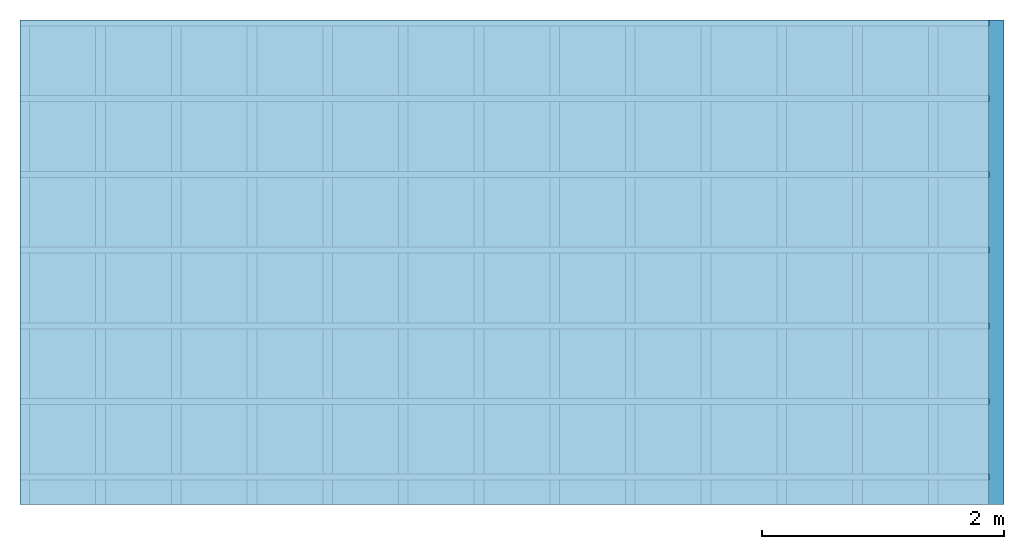
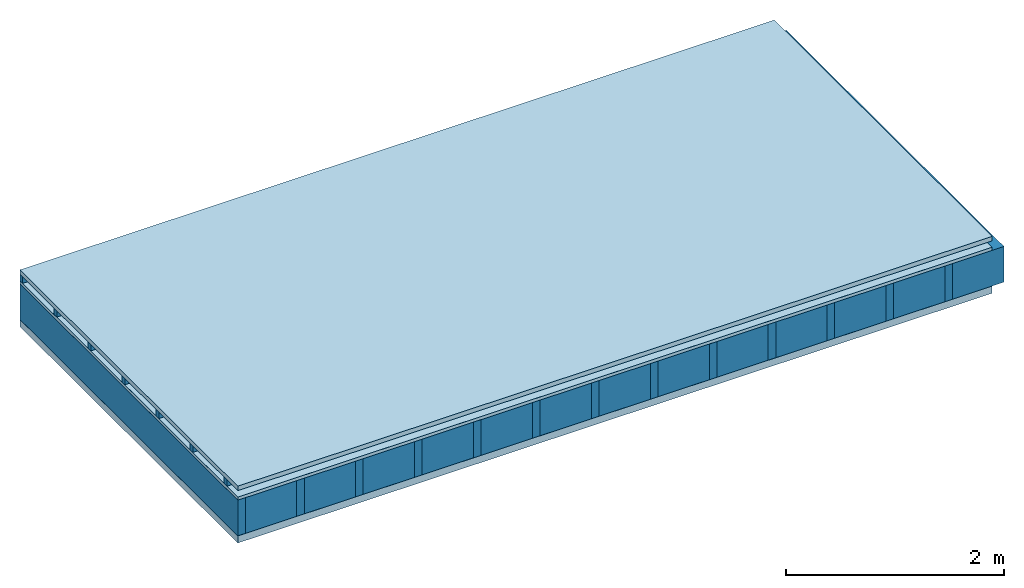
# One storey: 5 plates, 3 members, 1 element without a shape of its own.
"""IFC4 building model written with IfcOpenShell, lengths in metres."""

from ifc_helpers import new_model, si_unit, derived_unit, direction, frame, frame_2d, origin, origin_with_axes, place, context, project, spatial, rectangle, extrude, material, layer, layer_set, type_object, element, aggregate, save


model = new_model("IFC4")

# Units and contexts
plan_context = context("Plan", 3, precision=1e-05, world=origin(), true_north=direction((0.0, 1.0)))
model_context = context("Model", 3, precision=1e-05, world=origin(), true_north=direction((0.0, 1.0)))
ifc_project = project(units=[si_unit("LENGTHUNIT", "METRE"), derived_unit("SOUNDPRESSUREUNIT", [(si_unit("PRESSUREUNIT", "PASCAL", prefix="MICRO"), 0)]), si_unit("ENERGYUNIT", "JOULE", prefix="MEGA"), si_unit("MASSUNIT", "GRAM", prefix="KILO"), derived_unit("THERMALTRANSMITTANCEUNIT", [(si_unit("POWERUNIT", "WATT"), 1), (si_unit("AREAUNIT", "SQUARE_METRE"), -1), (si_unit("THERMODYNAMICTEMPERATUREUNIT", "KELVIN"), -1)]), derived_unit("AREADENSITYUNIT", [(si_unit("MASSUNIT", "GRAM", prefix="KILO"), 1), (si_unit("AREAUNIT", "SQUARE_METRE"), -1)]), derived_unit("USERDEFINED", [(si_unit("ENERGYUNIT", "JOULE", prefix="MEGA"), 1), (si_unit("AREAUNIT", "SQUARE_METRE"), -1)])], contexts=[plan_context, model_context])

# Site, building, storey
site = spatial("IfcSite", under=ifc_project)
building_placement = place(None, origin())
building = spatial("IfcBuilding", under=site, at=building_placement)
storey_placement = place(building_placement, origin())
storey = spatial("IfcBuildingStorey", under=building, at=storey_placement)

# Slab, members, plates
ifc_material_1 = material(Name="Roof tiles", Category="03.015")
ifc_layer_1 = layer(ifc_material_1, 0.05, Name="Roofing")
ifc_layer_2 = layer(None, 0.072, Name="Battens / profiles")
ifc_material_2 = material(Name="Roofing underlay", Category="09.008")
ifc_layer_3 = layer(ifc_material_2, 0.00018, Name="Under the roof")
ifc_material_3 = material(Category="10.009")
ifc_layer_4 = layer(ifc_material_3, 0.035, Name="Sub-floor")
ifc_material_4 = material(Name="of the art")
ifc_layer_5 = layer(ifc_material_4, 0.0, Name="Bond")
ifc_layer_6 = layer(None, 0.4, Name="Supporting structure")
ifc_material_5 = material(Name="Vapor barrier polyethylene (PE)", Category="09.002")
ifc_layer_7 = layer(ifc_material_5, 0.00025, Name="Lower layer 1")
ifc_material_6 = material(Name="Solid timber panel")
ifc_layer_8 = layer(ifc_material_6, 0.08, Name="Lower 2nd layer")
ifc_layer_set = layer_set([ifc_layer_1, ifc_layer_2, ifc_layer_3, ifc_layer_4, ifc_layer_5, ifc_layer_6, ifc_layer_7, ifc_layer_8])
slab_type = type_object("IfcSlabType", Name="E0151", PredefinedType="NOTDEFINED", material=ifc_layer_set)
slab_placement = place(None, frame((0.0, 0.0, 0.0), z_axis=(0.0, 0.0, -1.0), x_axis=(1.0, 0.0, 0.0)))
slab = element("IfcSlab", 1, at=slab_placement, inside=storey, type_object=slab_type, material=ifc_layer_set, Name="Slab #1")
ifc_material_7 = material()
member_1_placement = place(slab_placement, origin())
member_1 = element("IfcMember", 2, at=member_1_placement, material=ifc_material_7, Name="Battens / profiles", context=plan_context, shape_type="SweptSolid", body=[
    extrude(rectangle(XDim=0.05, YDim=0.072, at=frame_2d((0.025, 0.036), x_axis=(1.0, 0.0))), frame((0.0, 0.0, 0.05), z_axis=(1.0, 0.0, 0.0), x_axis=(0.0, 1.0, 0.0)), (0.0, 0.0, 1.0), 8.0),
    extrude(rectangle(XDim=0.05, YDim=0.072, at=frame_2d((0.025, 0.036), x_axis=(1.0, 0.0))), frame((0.0, 0.625, 0.05), z_axis=(1.0, 0.0, 0.0), x_axis=(0.0, 1.0, 0.0)), (0.0, 0.0, 1.0), 8.0),
    extrude(rectangle(XDim=0.05, YDim=0.072, at=frame_2d((0.025, 0.036), x_axis=(1.0, 0.0))), frame((0.0, 1.25, 0.05), z_axis=(1.0, 0.0, 0.0), x_axis=(0.0, 1.0, 0.0)), (0.0, 0.0, 1.0), 8.0),
    extrude(rectangle(XDim=0.05, YDim=0.072, at=frame_2d((0.025, 0.036), x_axis=(1.0, 0.0))), frame((0.0, 1.875, 0.05), z_axis=(1.0, 0.0, 0.0), x_axis=(0.0, 1.0, 0.0)), (0.0, 0.0, 1.0), 8.0),
    extrude(rectangle(XDim=0.05, YDim=0.072, at=frame_2d((0.025, 0.036), x_axis=(1.0, 0.0))), frame((0.0, 2.5, 0.05), z_axis=(1.0, 0.0, 0.0), x_axis=(0.0, 1.0, 0.0)), (0.0, 0.0, 1.0), 8.0),
    extrude(rectangle(XDim=0.05, YDim=0.072, at=frame_2d((0.025, 0.036), x_axis=(1.0, 0.0))), frame((0.0, 3.125, 0.05), z_axis=(1.0, 0.0, 0.0), x_axis=(0.0, 1.0, 0.0)), (0.0, 0.0, 1.0), 8.0),
    extrude(rectangle(XDim=0.05, YDim=0.072, at=frame_2d((0.025, 0.036), x_axis=(1.0, 0.0))), frame((0.0, 3.75, 0.05), z_axis=(1.0, 0.0, 0.0), x_axis=(0.0, 1.0, 0.0)), (0.0, 0.0, 1.0), 8.0),
])
ifc_material_8 = material()
member_2_placement = place(slab_placement, origin())
member_2 = element("IfcMember", 3, at=member_2_placement, material=ifc_material_8, Name="Supporting structure", context=plan_context, shape_type="SweptSolid", body=[
    extrude(rectangle(XDim=0.08, YDim=0.4, at=frame_2d((0.04, 0.2), x_axis=(1.0, 0.0))), frame((0.0, 4.0, 0.15718), z_axis=(0.0, -1.0, 0.0), x_axis=(1.0, 0.0, 0.0)), (0.0, 0.0, 1.0), 4.0),
    extrude(rectangle(XDim=0.08, YDim=0.4, at=frame_2d((0.04, 0.2), x_axis=(1.0, 0.0))), frame((0.625, 4.0, 0.15718), z_axis=(0.0, -1.0, 0.0), x_axis=(1.0, 0.0, 0.0)), (0.0, 0.0, 1.0), 4.0),
    extrude(rectangle(XDim=0.08, YDim=0.4, at=frame_2d((0.04, 0.2), x_axis=(1.0, 0.0))), frame((1.25, 4.0, 0.15718), z_axis=(0.0, -1.0, 0.0), x_axis=(1.0, 0.0, 0.0)), (0.0, 0.0, 1.0), 4.0),
    extrude(rectangle(XDim=0.08, YDim=0.4, at=frame_2d((0.04, 0.2), x_axis=(1.0, 0.0))), frame((1.875, 4.0, 0.15718), z_axis=(0.0, -1.0, 0.0), x_axis=(1.0, 0.0, 0.0)), (0.0, 0.0, 1.0), 4.0),
    extrude(rectangle(XDim=0.08, YDim=0.4, at=frame_2d((0.04, 0.2), x_axis=(1.0, 0.0))), frame((2.5, 4.0, 0.15718), z_axis=(0.0, -1.0, 0.0), x_axis=(1.0, 0.0, 0.0)), (0.0, 0.0, 1.0), 4.0),
    extrude(rectangle(XDim=0.08, YDim=0.4, at=frame_2d((0.04, 0.2), x_axis=(1.0, 0.0))), frame((3.125, 4.0, 0.15718), z_axis=(0.0, -1.0, 0.0), x_axis=(1.0, 0.0, 0.0)), (0.0, 0.0, 1.0), 4.0),
    extrude(rectangle(XDim=0.08, YDim=0.4, at=frame_2d((0.04, 0.2), x_axis=(1.0, 0.0))), frame((3.75, 4.0, 0.15718), z_axis=(0.0, -1.0, 0.0), x_axis=(1.0, 0.0, 0.0)), (0.0, 0.0, 1.0), 4.0),
    extrude(rectangle(XDim=0.08, YDim=0.4, at=frame_2d((0.04, 0.2), x_axis=(1.0, 0.0))), frame((4.375, 4.0, 0.15718), z_axis=(0.0, -1.0, 0.0), x_axis=(1.0, 0.0, 0.0)), (0.0, 0.0, 1.0), 4.0),
    extrude(rectangle(XDim=0.08, YDim=0.4, at=frame_2d((0.04, 0.2), x_axis=(1.0, 0.0))), frame((5.0, 4.0, 0.15718), z_axis=(0.0, -1.0, 0.0), x_axis=(1.0, 0.0, 0.0)), (0.0, 0.0, 1.0), 4.0),
    extrude(rectangle(XDim=0.08, YDim=0.4, at=frame_2d((0.04, 0.2), x_axis=(1.0, 0.0))), frame((5.625, 4.0, 0.15718), z_axis=(0.0, -1.0, 0.0), x_axis=(1.0, 0.0, 0.0)), (0.0, 0.0, 1.0), 4.0),
    extrude(rectangle(XDim=0.08, YDim=0.4, at=frame_2d((0.04, 0.2), x_axis=(1.0, 0.0))), frame((6.25, 4.0, 0.15718), z_axis=(0.0, -1.0, 0.0), x_axis=(1.0, 0.0, 0.0)), (0.0, 0.0, 1.0), 4.0),
    extrude(rectangle(XDim=0.08, YDim=0.4, at=frame_2d((0.04, 0.2), x_axis=(1.0, 0.0))), frame((6.875, 4.0, 0.15718), z_axis=(0.0, -1.0, 0.0), x_axis=(1.0, 0.0, 0.0)), (0.0, 0.0, 1.0), 4.0),
    extrude(rectangle(XDim=0.08, YDim=0.4, at=frame_2d((0.04, 0.2), x_axis=(1.0, 0.0))), frame((7.5, 4.0, 0.15718), z_axis=(0.0, -1.0, 0.0), x_axis=(1.0, 0.0, 0.0)), (0.0, 0.0, 1.0), 4.0),
])
ifc_material_9 = material()
member_3_placement = place(slab_placement, origin())
member_3 = element("IfcMember", 4, at=member_3_placement, material=ifc_material_9, Name="Cavity", context=plan_context, shape_type="SweptSolid", body=[
    extrude(rectangle(XDim=0.545, YDim=0.4, at=frame_2d((0.2725, 0.2), x_axis=(1.0, 0.0))), frame((0.08, 4.0, 0.15718), z_axis=(0.0, -1.0, 0.0), x_axis=(1.0, 0.0, 0.0)), (0.0, 0.0, 1.0), 4.0),
    extrude(rectangle(XDim=0.545, YDim=0.4, at=frame_2d((0.2725, 0.2), x_axis=(1.0, 0.0))), frame((0.705, 4.0, 0.15718), z_axis=(0.0, -1.0, 0.0), x_axis=(1.0, 0.0, 0.0)), (0.0, 0.0, 1.0), 4.0),
    extrude(rectangle(XDim=0.545, YDim=0.4, at=frame_2d((0.2725, 0.2), x_axis=(1.0, 0.0))), frame((1.33, 4.0, 0.15718), z_axis=(0.0, -1.0, 0.0), x_axis=(1.0, 0.0, 0.0)), (0.0, 0.0, 1.0), 4.0),
    extrude(rectangle(XDim=0.545, YDim=0.4, at=frame_2d((0.2725, 0.2), x_axis=(1.0, 0.0))), frame((1.955, 4.0, 0.15718), z_axis=(0.0, -1.0, 0.0), x_axis=(1.0, 0.0, 0.0)), (0.0, 0.0, 1.0), 4.0),
    extrude(rectangle(XDim=0.545, YDim=0.4, at=frame_2d((0.2725, 0.2), x_axis=(1.0, 0.0))), frame((2.58, 4.0, 0.15718), z_axis=(0.0, -1.0, 0.0), x_axis=(1.0, 0.0, 0.0)), (0.0, 0.0, 1.0), 4.0),
    extrude(rectangle(XDim=0.545, YDim=0.4, at=frame_2d((0.2725, 0.2), x_axis=(1.0, 0.0))), frame((3.205, 4.0, 0.15718), z_axis=(0.0, -1.0, 0.0), x_axis=(1.0, 0.0, 0.0)), (0.0, 0.0, 1.0), 4.0),
    extrude(rectangle(XDim=0.545, YDim=0.4, at=frame_2d((0.2725, 0.2), x_axis=(1.0, 0.0))), frame((3.83, 4.0, 0.15718), z_axis=(0.0, -1.0, 0.0), x_axis=(1.0, 0.0, 0.0)), (0.0, 0.0, 1.0), 4.0),
    extrude(rectangle(XDim=0.545, YDim=0.4, at=frame_2d((0.2725, 0.2), x_axis=(1.0, 0.0))), frame((4.455, 4.0, 0.15718), z_axis=(0.0, -1.0, 0.0), x_axis=(1.0, 0.0, 0.0)), (0.0, 0.0, 1.0), 4.0),
    extrude(rectangle(XDim=0.545, YDim=0.4, at=frame_2d((0.2725, 0.2), x_axis=(1.0, 0.0))), frame((5.08, 4.0, 0.15718), z_axis=(0.0, -1.0, 0.0), x_axis=(1.0, 0.0, 0.0)), (0.0, 0.0, 1.0), 4.0),
    extrude(rectangle(XDim=0.545, YDim=0.4, at=frame_2d((0.2725, 0.2), x_axis=(1.0, 0.0))), frame((5.705, 4.0, 0.15718), z_axis=(0.0, -1.0, 0.0), x_axis=(1.0, 0.0, 0.0)), (0.0, 0.0, 1.0), 4.0),
    extrude(rectangle(XDim=0.545, YDim=0.4, at=frame_2d((0.2725, 0.2), x_axis=(1.0, 0.0))), frame((6.33, 4.0, 0.15718), z_axis=(0.0, -1.0, 0.0), x_axis=(1.0, 0.0, 0.0)), (0.0, 0.0, 1.0), 4.0),
    extrude(rectangle(XDim=0.545, YDim=0.4, at=frame_2d((0.2725, 0.2), x_axis=(1.0, 0.0))), frame((6.955, 4.0, 0.15718), z_axis=(0.0, -1.0, 0.0), x_axis=(1.0, 0.0, 0.0)), (0.0, 0.0, 1.0), 4.0),
    extrude(rectangle(XDim=0.545, YDim=0.4, at=frame_2d((0.2725, 0.2), x_axis=(1.0, 0.0))), frame((7.58, 4.0, 0.15718), z_axis=(0.0, -1.0, 0.0), x_axis=(1.0, 0.0, 0.0)), (0.0, 0.0, 1.0), 4.0),
])
plate_1_placement = place(slab_placement, origin())
plate_1 = element("IfcPlate", 5, at=plate_1_placement, material=ifc_material_1, Name="Roofing", context=plan_context, shape_type="SweptSolid", body=[
    extrude(rectangle(XDim=8.0, YDim=4.0, at=frame_2d((4.0, 2.0), x_axis=(1.0, 0.0))), origin_with_axes(), (0.0, 0.0, 1.0), 0.05),
])
plate_2_placement = place(slab_placement, origin())
plate_2 = element("IfcPlate", 6, at=plate_2_placement, material=ifc_material_2, Name="Under the roof", context=plan_context, shape_type="SweptSolid", body=[
    extrude(rectangle(XDim=8.0, YDim=4.0, at=frame_2d((4.0, 2.0), x_axis=(1.0, 0.0))), frame((0.0, 0.0, 0.122), z_axis=(0.0, 0.0, 1.0), x_axis=(1.0, 0.0, 0.0)), (0.0, 0.0, 1.0), 0.00018),
])
plate_3_placement = place(slab_placement, origin())
plate_3 = element("IfcPlate", 7, at=plate_3_placement, material=ifc_material_3, Name="Sub-floor", context=plan_context, shape_type="SweptSolid", body=[
    extrude(rectangle(XDim=8.0, YDim=4.0, at=frame_2d((4.0, 2.0), x_axis=(1.0, 0.0))), frame((0.0, 0.0, 0.12218), z_axis=(0.0, 0.0, 1.0), x_axis=(1.0, 0.0, 0.0)), (0.0, 0.0, 1.0), 0.035),
])
plate_4_placement = place(slab_placement, origin())
plate_4 = element("IfcPlate", 8, at=plate_4_placement, material=ifc_material_5, Name="Lower layer 1", context=plan_context, shape_type="SweptSolid", body=[
    extrude(rectangle(XDim=8.0, YDim=4.0, at=frame_2d((4.0, 2.0), x_axis=(1.0, 0.0))), frame((0.0, 0.0, 0.55718), z_axis=(0.0, 0.0, 1.0), x_axis=(1.0, 0.0, 0.0)), (0.0, 0.0, 1.0), 0.00025),
])
plate_5_placement = place(slab_placement, origin())
plate_5 = element("IfcPlate", 9, at=plate_5_placement, material=ifc_material_6, Name="Lower 2nd layer", context=plan_context, shape_type="SweptSolid", body=[
    extrude(rectangle(XDim=8.0, YDim=4.0, at=frame_2d((4.0, 2.0), x_axis=(1.0, 0.0))), frame((0.0, 0.0, 0.55743), z_axis=(0.0, 0.0, 1.0), x_axis=(1.0, 0.0, 0.0)), (0.0, 0.0, 1.0), 0.08),
])
aggregate(slab, [plate_1, member_1, plate_2, plate_3, member_2, member_3, plate_4, plate_5])

save(model, "model.ifc")
